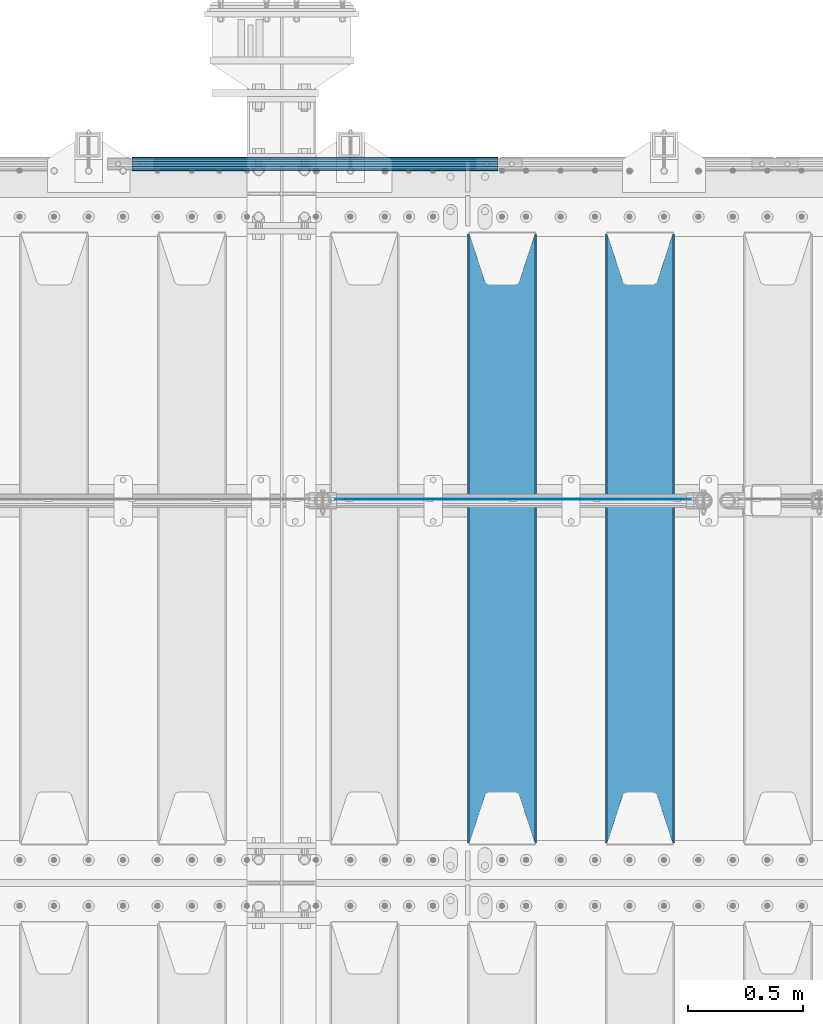
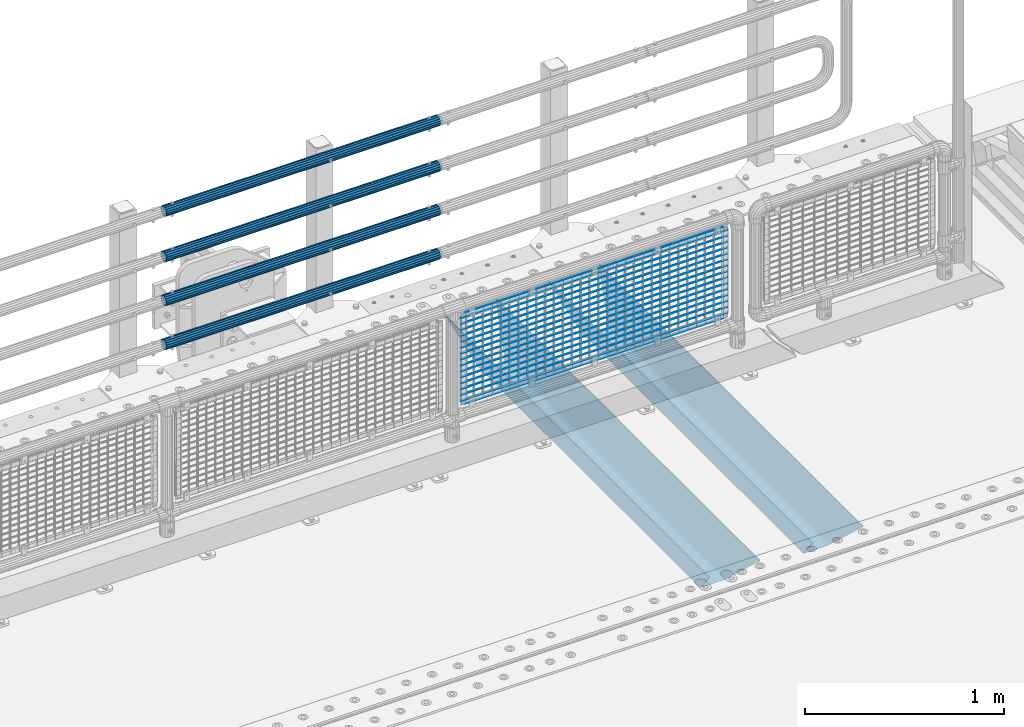
# One storey, part 100 of 193: 23 beams.
"""IFC2X3 building model written with IfcOpenShell, lengths in millimetres."""

from ifc_helpers import new_model, si_unit, frame, origin_with_axes, place, context, subcontext, project, spatial, faceted_brep, material, type_object, element, save


model = new_model("IFC2X3")

# Units and contexts
model_context = context("Model", 3, precision=1e-05, world=origin_with_axes())
body_context = subcontext(model_context, "Body", "Model", "MODEL_VIEW")
ifc_project = project(units=[si_unit("LENGTHUNIT", "METRE", prefix="MILLI"), si_unit("AREAUNIT", "SQUARE_METRE"), si_unit("VOLUMEUNIT", "CUBIC_METRE"), si_unit("MASSUNIT", "GRAM", prefix="KILO"), si_unit("TIMEUNIT", "SECOND"), si_unit("PLANEANGLEUNIT", "RADIAN"), si_unit("SOLIDANGLEUNIT", "STERADIAN"), si_unit("THERMODYNAMICTEMPERATUREUNIT", "DEGREE_CELSIUS"), si_unit("LUMINOUSINTENSITYUNIT", "LUMEN")], contexts=[model_context])

# Site, building, storey
site_placement = place(None, origin_with_axes())
site = spatial("IfcSite", under=ifc_project, at=site_placement, CompositionType="ELEMENT")
building_placement = place(site_placement, origin_with_axes())
building = spatial("IfcBuilding", under=site, at=building_placement, Name="Standard", CompositionType="ELEMENT")
storey_placement = place(building_placement, origin_with_axes())
storey = spatial("IfcBuildingStorey", under=building, at=storey_placement, Name="Undefined", CompositionType="ELEMENT", Elevation=0.0)

# Beams
ifc_material_1 = material(Name="STEEL/S355N")
beam_type_1 = type_object("IfcBeamType", PredefinedType="NOTDEFINED")
beam_1_placement = place(storey_placement, frame((-30500.0, 27175.0, -115.0), z_axis=(0.0, 0.0, 1.0), x_axis=(0.0, 1.0, 0.0)))
element("IfcBeam", 1, at=beam_1_placement, inside=storey, type_object=beam_type_1, material=ifc_material_1, context=body_context, shape_type="Brep", body=[
    faceted_brep([(0.0, 150.0, 115.0), (0.0, 143.689999999999, 115.0), (2650.00000000297, 143.689999999999, 115.0), (2650.00000000297, 150.0, 115.0), (2650.00000000297, 142.059565218398, 110.000000003094), (2650.00000000297, 148.3695652184, 110.000000003094), (2441.90079219209, -80.1103600731112, -98.0992078077845), (2437.7588105432, -77.5672621345584, -102.241189456673), (2434.06523489747, -74.4080125315522, -105.934765102404), (2430.9108609509, -70.710272125576, -109.089139048974), (2428.37322971128, -66.5649389910068, -111.626770288588), (2426.51472138055, -62.0739139532889, -113.485278619323), (2425.38102192092, -57.3475956567672, -114.618978078955), (2424.99999999988, -52.5021667386536, -115.0), (2424.99999999988, 52.5021667386536, -115.0), (2425.38102192092, 57.3475956567672, -114.618978078955), (2426.51472138055, 62.0739139532889, -113.485278619323), (2428.37322971128, 66.5649389910068, -111.626770288588), (2430.9108609509, 70.710272125576, -109.089139048974), (2434.06523489747, 74.4080125315522, -105.934765102404), (2437.7588105432, 77.5672621345584, -102.241189456673), (2441.90079219209, 80.1103600731112, -98.0992078077846), (2446.38936140512, 81.9747917625791, -93.6106385947584), (2448.2494850041, 76.2713538057251, -91.7505149957729), (2444.62967112263, 74.76777986261, -95.3703288772456), (2441.28936334127, 72.7168944282894, -98.710636658607), (2438.31067330439, 70.1691124903846, -101.689326695487), (2435.76682334748, 67.1870637758839, -104.233176652398), (2433.72034654134, 63.8440531834895, -106.279653458539), (2432.22154950042, 60.222258798236, -107.778450499454), (2431.30727574265, 56.4107117849089, -108.692724257221), (2430.99999999987, 52.5031078186876, -109.0), (2430.99999999987, -52.5031078186876, -109.0), (2431.30727574265, -56.4107117849089, -108.692724257221), (2432.22154950042, -60.222258798236, -107.778450499454), (2433.72034654134, -63.8440531834895, -106.279653458539), (2435.76682334748, -67.1870637758839, -104.233176652398), (2438.31067330439, -70.1691124903846, -101.689326695487), (2441.28936334127, -72.7168944282894, -98.7106366586071), (2444.62967112263, -74.76777986261, -95.3703288772457), (2448.2494850041, -76.2713538057251, -91.7505149957729), (2650.00000000297, -142.059565218398, 110.000000003094), (2650.00000000297, -148.3695652184, 110.000000003094), (2446.38936140512, -81.9747917625791, -93.6106385947584), (2650.00000000297, -143.689999999999, 115.0), (2650.00000000297, -150.0, 115.0), (0.0, -143.689999999999, 115.0), (0.0, -150.0, 115.0), (0.0, -148.369565218261, 110.000000002667), (203.610638597427, -81.9747917625791, -93.6106385947584), (208.099207810446, -80.1103600731112, -98.0992078077845), (212.241189459342, -77.5672621345584, -102.241189456673), (215.93476510507, -74.4080125315522, -105.934765102404), (219.089139051641, -70.710272125576, -109.089139048974), (221.626770291256, -66.5649389910068, -111.626770288588), (223.485278621989, -62.0739139532889, -113.485278619323), (224.618978081624, -57.3475956567672, -114.618978078955), (225.000000002663, -52.5021667386536, -115.0), (225.000000002663, 52.5021667386536, -115.0), (224.618978081624, 57.3475956567672, -114.618978078955), (223.485278621989, 62.0739139532889, -113.485278619323), (221.626770291256, 66.5649389910068, -111.626770288588), (219.089139051641, 70.710272125576, -109.089139048974), (215.93476510507, 74.4080125315522, -105.934765102404), (212.241189459342, 77.5672621345584, -102.241189456673), (208.099207810446, 80.1103600731112, -98.0992078077846), (203.610638597427, 81.9747917625791, -93.6106385947584), (0.0, 148.369565218261, 110.000000002667), (0.0, 142.05956521826, 110.000000002667), (201.750514998439, 76.2713538057251, -91.7505149957729), (205.370328879915, 74.76777986261, -95.3703288772456), (208.710636661275, 72.7168944282894, -98.710636658607), (211.689326698157, 70.1691124903846, -101.689326695487), (214.233176655063, 67.1870637758839, -104.233176652398), (216.279653461206, 63.8440531834895, -106.279653458539), (217.778450502123, 60.222258798236, -107.778450499454), (218.69272425989, 56.4107117849089, -108.692724257221), (219.00000000267, 52.5031078186876, -109.0), (219.00000000267, -52.5031078186876, -109.0), (218.69272425989, -56.4107117849089, -108.692724257221), (217.778450502123, -60.222258798236, -107.778450499454), (216.279653461206, -63.8440531834895, -106.279653458539), (214.233176655063, -67.1870637758839, -104.233176652398), (211.689326698157, -70.1691124903846, -101.689326695487), (208.710636661275, -72.7168944282894, -98.7106366586071), (205.370328879915, -74.76777986261, -95.3703288772457), (201.750514998439, -76.2713538057251, -91.7505149957729), (0.0, -142.05956521826, 110.000000002667)], [[[0, 1, 2, 3]], [[3, 2, 4, 5]], [[6, 7, 8, 9, 10, 11, 12, 13, 14, 15, 16, 17, 18, 19, 20, 21, 22, 5, 4, 23, 24, 25, 26, 27, 28, 29, 30, 31, 32, 33, 34, 35, 36, 37, 38, 39, 40, 41, 42, 43]], [[44, 45, 42, 41]], [[46, 47, 45, 44]], [[43, 42, 45, 47, 48, 49]], [[6, 43, 49, 50]], [[7, 6, 50, 51]], [[8, 7, 51, 52]], [[9, 8, 52, 53]], [[10, 9, 53, 54]], [[11, 10, 54, 55]], [[12, 11, 55, 56]], [[13, 12, 56, 57]], [[14, 13, 57, 58]], [[15, 14, 58, 59]], [[16, 15, 59, 60]], [[17, 16, 60, 61]], [[18, 17, 61, 62]], [[19, 18, 62, 63]], [[20, 19, 63, 64]], [[21, 20, 64, 65]], [[22, 21, 65, 66]], [[0, 3, 5, 22, 66, 67]], [[1, 0, 67, 68]], [[23, 4, 2, 1, 68, 69]], [[24, 23, 69, 70]], [[25, 24, 70, 71]], [[26, 25, 71, 72]], [[27, 26, 72, 73]], [[28, 27, 73, 74]], [[29, 28, 74, 75]], [[30, 29, 75, 76]], [[31, 30, 76, 77]], [[32, 31, 77, 78]], [[33, 32, 78, 79]], [[34, 33, 79, 80]], [[35, 34, 80, 81]], [[36, 35, 81, 82]], [[37, 36, 82, 83]], [[38, 37, 83, 84]], [[39, 38, 84, 85]], [[40, 39, 85, 86]], [[46, 44, 41, 40, 86, 87]], [[47, 46, 87, 48]], [[86, 85, 84, 83, 82, 81, 80, 79, 78, 77, 76, 75, 74, 73, 72, 71, 70, 69, 68, 67, 66, 65, 64, 63, 62, 61, 60, 59, 58, 57, 56, 55, 54, 53, 52, 51, 50, 49, 48, 87]]]),
])
beam_2_placement = place(storey_placement, frame((-31100.0, 27175.0, -115.0), z_axis=(0.0, 0.0, 1.0), x_axis=(0.0, 1.0, 0.0)))
element("IfcBeam", 2, at=beam_2_placement, inside=storey, type_object=beam_type_1, material=ifc_material_1, context=body_context, shape_type="Brep", body=[
    faceted_brep([(0.0, 150.0, 115.0), (0.0, 143.689999999999, 115.0), (2650.00000000297, 143.689999999999, 115.0), (2650.00000000297, 150.0, 115.0), (2650.00000000297, 142.059565218398, 110.000000003094), (2650.00000000297, 148.3695652184, 110.000000003094), (2441.90079219209, -80.1103600731112, -98.0992078077845), (2437.7588105432, -77.5672621345584, -102.241189456673), (2434.06523489747, -74.4080125315522, -105.934765102404), (2430.9108609509, -70.710272125576, -109.089139048974), (2428.37322971128, -66.5649389910068, -111.626770288588), (2426.51472138055, -62.0739139532889, -113.485278619323), (2425.38102192092, -57.3475956567672, -114.618978078955), (2424.99999999988, -52.5021667386536, -115.0), (2424.99999999988, 52.5021667386536, -115.0), (2425.38102192092, 57.3475956567672, -114.618978078955), (2426.51472138055, 62.0739139532889, -113.485278619323), (2428.37322971128, 66.5649389910068, -111.626770288588), (2430.9108609509, 70.710272125576, -109.089139048974), (2434.06523489747, 74.4080125315522, -105.934765102404), (2437.7588105432, 77.5672621345584, -102.241189456673), (2441.90079219209, 80.1103600731112, -98.0992078077846), (2446.38936140512, 81.9747917625791, -93.6106385947584), (2448.2494850041, 76.2713538057251, -91.7505149957729), (2444.62967112263, 74.76777986261, -95.3703288772456), (2441.28936334127, 72.7168944282894, -98.710636658607), (2438.31067330439, 70.1691124903846, -101.689326695487), (2435.76682334748, 67.1870637758839, -104.233176652398), (2433.72034654134, 63.8440531834895, -106.279653458539), (2432.22154950042, 60.222258798236, -107.778450499454), (2431.30727574265, 56.4107117849089, -108.692724257221), (2430.99999999987, 52.5031078186876, -109.0), (2430.99999999987, -52.5031078186876, -109.0), (2431.30727574265, -56.4107117849089, -108.692724257221), (2432.22154950042, -60.222258798236, -107.778450499454), (2433.72034654134, -63.8440531834895, -106.279653458539), (2435.76682334748, -67.1870637758839, -104.233176652398), (2438.31067330439, -70.1691124903846, -101.689326695487), (2441.28936334127, -72.7168944282894, -98.7106366586071), (2444.62967112263, -74.76777986261, -95.3703288772457), (2448.2494850041, -76.2713538057251, -91.7505149957729), (2650.00000000297, -142.059565218398, 110.000000003094), (2650.00000000297, -148.3695652184, 110.000000003094), (2446.38936140512, -81.9747917625791, -93.6106385947584), (2650.00000000297, -143.689999999999, 115.0), (2650.00000000297, -150.0, 115.0), (0.0, -143.689999999999, 115.0), (0.0, -150.0, 115.0), (0.0, -148.369565218261, 110.000000002667), (203.610638597427, -81.9747917625791, -93.6106385947584), (208.099207810446, -80.1103600731112, -98.0992078077845), (212.241189459342, -77.5672621345584, -102.241189456673), (215.93476510507, -74.4080125315522, -105.934765102404), (219.089139051641, -70.710272125576, -109.089139048974), (221.626770291256, -66.5649389910068, -111.626770288588), (223.485278621989, -62.0739139532889, -113.485278619323), (224.618978081624, -57.3475956567672, -114.618978078955), (225.000000002663, -52.5021667386536, -115.0), (225.000000002663, 52.5021667386536, -115.0), (224.618978081624, 57.3475956567672, -114.618978078955), (223.485278621989, 62.0739139532889, -113.485278619323), (221.626770291256, 66.5649389910068, -111.626770288588), (219.089139051641, 70.710272125576, -109.089139048974), (215.93476510507, 74.4080125315522, -105.934765102404), (212.241189459342, 77.5672621345584, -102.241189456673), (208.099207810446, 80.1103600731112, -98.0992078077846), (203.610638597427, 81.9747917625791, -93.6106385947584), (0.0, 148.369565218261, 110.000000002667), (0.0, 142.05956521826, 110.000000002667), (201.750514998439, 76.2713538057251, -91.7505149957729), (205.370328879915, 74.76777986261, -95.3703288772456), (208.710636661275, 72.7168944282894, -98.710636658607), (211.689326698157, 70.1691124903846, -101.689326695487), (214.233176655063, 67.1870637758839, -104.233176652398), (216.279653461206, 63.8440531834895, -106.279653458539), (217.778450502123, 60.222258798236, -107.778450499454), (218.69272425989, 56.4107117849089, -108.692724257221), (219.00000000267, 52.5031078186876, -109.0), (219.00000000267, -52.5031078186876, -109.0), (218.69272425989, -56.4107117849089, -108.692724257221), (217.778450502123, -60.222258798236, -107.778450499454), (216.279653461206, -63.8440531834895, -106.279653458539), (214.233176655063, -67.1870637758839, -104.233176652398), (211.689326698157, -70.1691124903846, -101.689326695487), (208.710636661275, -72.7168944282894, -98.7106366586071), (205.370328879915, -74.76777986261, -95.3703288772457), (201.750514998439, -76.2713538057251, -91.7505149957729), (0.0, -142.05956521826, 110.000000002667)], [[[0, 1, 2, 3]], [[3, 2, 4, 5]], [[6, 7, 8, 9, 10, 11, 12, 13, 14, 15, 16, 17, 18, 19, 20, 21, 22, 5, 4, 23, 24, 25, 26, 27, 28, 29, 30, 31, 32, 33, 34, 35, 36, 37, 38, 39, 40, 41, 42, 43]], [[44, 45, 42, 41]], [[46, 47, 45, 44]], [[43, 42, 45, 47, 48, 49]], [[6, 43, 49, 50]], [[7, 6, 50, 51]], [[8, 7, 51, 52]], [[9, 8, 52, 53]], [[10, 9, 53, 54]], [[11, 10, 54, 55]], [[12, 11, 55, 56]], [[13, 12, 56, 57]], [[14, 13, 57, 58]], [[15, 14, 58, 59]], [[16, 15, 59, 60]], [[17, 16, 60, 61]], [[18, 17, 61, 62]], [[19, 18, 62, 63]], [[20, 19, 63, 64]], [[21, 20, 64, 65]], [[22, 21, 65, 66]], [[0, 3, 5, 22, 66, 67]], [[1, 0, 67, 68]], [[23, 4, 2, 1, 68, 69]], [[24, 23, 69, 70]], [[25, 24, 70, 71]], [[26, 25, 71, 72]], [[27, 26, 72, 73]], [[28, 27, 73, 74]], [[29, 28, 74, 75]], [[30, 29, 75, 76]], [[31, 30, 76, 77]], [[32, 31, 77, 78]], [[33, 32, 78, 79]], [[34, 33, 79, 80]], [[35, 34, 80, 81]], [[36, 35, 81, 82]], [[37, 36, 82, 83]], [[38, 37, 83, 84]], [[39, 38, 84, 85]], [[40, 39, 85, 86]], [[46, 44, 41, 40, 86, 87]], [[47, 46, 87, 48]], [[86, 85, 84, 83, 82, 81, 80, 79, 78, 77, 76, 75, 74, 73, 72, 71, 70, 69, 68, 67, 66, 65, 64, 63, 62, 61, 60, 59, 58, 57, 56, 55, 54, 53, 52, 51, 50, 49, 48, 87]]]),
])
ifc_material_2 = material()
beam_type_2 = type_object("IfcBeamType", PredefinedType="NOTDEFINED")
beam_3_placement = place(storey_placement, frame((-31118.0000000001, 30129.8500000002, 149.849999999748), z_axis=(0.0, 0.0, -1.0), x_axis=(-1.0, 0.0, 0.0)))
element("IfcBeam", 3, at=beam_3_placement, inside=storey, type_object=beam_type_2, material=ifc_material_2, context=body_context, shape_type="Brep", body=[
    faceted_brep([(0.0, -26.5499999999993, 0.0), (0.0, -24.5290015881765, 10.1602451292931), (1594.0, -24.5290015881765, 10.1602451292931), (1594.0, -26.5499999999993, 0.0), (0.0, -18.7736850405017, 18.7736850405028), (1594.0, -18.7736850405017, 18.7736850405028), (0.0, -10.1602451292929, 24.5290015881747), (1594.0, -10.1602451292929, 24.5290015881747), (0.0, 0.0, 26.55), (1594.0, 0.0, 26.55), (0.0, 10.1602451292929, 24.5290015881747), (1594.0, 10.1602451292929, 24.5290015881747), (0.0, 18.7736850405017, 18.7736850405028), (1594.0, 18.7736850405017, 18.7736850405028), (0.0, 24.5290015881765, 10.1602451292931), (1594.0, 24.5290015881765, 10.1602451292931), (0.0, 26.5499999999993, 0.0), (1594.0, 26.5499999999993, 0.0), (0.0, 24.5290015881765, -10.1602451292931), (1594.0, 24.5290015881765, -10.1602451292931), (0.0, 18.7736850405017, -18.7736850405028), (1594.0, 18.7736850405017, -18.7736850405028), (0.0, 10.1602451292929, -24.5290015881747), (1594.0, 10.1602451292929, -24.5290015881747), (0.0, 0.0, -26.55), (1594.0, 0.0, -26.55), (0.0, -10.1602451292929, -24.5290015881747), (1594.0, -10.1602451292929, -24.5290015881747), (0.0, -18.7736850405017, -18.7736850405028), (1594.0, -18.7736850405017, -18.7736850405028), (0.0, -24.5290015881765, -10.1602451292931), (1594.0, -24.5290015881765, -10.1602451292931), (0.0, -30.1500000000015, 0.0), (0.0, -27.8549679052157, -11.5379054858058), (1594.0, -27.8549679052157, -11.5379054858075), (1594.0, -30.1500000000015, 0.0), (0.0, -21.3192694527752, -21.3192694527752), (1594.0, -21.3192694527752, -21.3192694527744), (0.0, -11.5379054858058, -27.8549679052157), (1594.0, -11.5379054858058, -27.8549679052153), (0.0, 0.0, -30.1500000000015), (1594.0, 0.0, -30.15), (0.0, 11.5379054858058, -27.8549679052157), (1594.0, 11.5379054858058, -27.8549679052153), (0.0, 21.3192694527752, -21.3192694527752), (1594.0, 21.3192694527752, -21.3192694527744), (0.0, 27.8549679052157, -11.5379054858058), (1594.0, 27.8549679052157, -11.5379054858074), (0.0, 30.1500000000015, 0.0), (1594.0, 30.1500000000015, 0.0), (0.0, 27.8549679052157, 11.5379054858058), (1594.0, 27.8549679052157, 11.5379054858075), (0.0, 21.3192694527752, 21.3192694527752), (1594.0, 21.3192694527752, 21.3192694527744), (0.0, 11.5379054858058, 27.8549679052157), (1594.0, 11.5379054858058, 27.8549679052153), (0.0, 0.0, 30.1500000000015), (1594.0, 0.0, 30.15), (0.0, -11.5379054858058, 27.8549679052157), (1594.0, -11.5379054858058, 27.8549679052153), (0.0, -21.3192694527752, 21.3192694527752), (1594.0, -21.3192694527752, 21.3192694527744), (0.0, -27.8549679052157, 11.5379054858058), (1594.0, -27.8549679052157, 11.5379054858075)], [[[0, 1, 2, 3]], [[1, 4, 5, 2]], [[4, 6, 7, 5]], [[6, 8, 9, 7]], [[8, 10, 11, 9]], [[10, 12, 13, 11]], [[12, 14, 15, 13]], [[14, 16, 17, 15]], [[16, 18, 19, 17]], [[18, 20, 21, 19]], [[20, 22, 23, 21]], [[22, 24, 25, 23]], [[24, 26, 27, 25]], [[26, 28, 29, 27]], [[28, 30, 31, 29]], [[30, 0, 3, 31]], [[32, 33, 34, 35]], [[33, 36, 37, 34]], [[36, 38, 39, 37]], [[38, 40, 41, 39]], [[40, 42, 43, 41]], [[42, 44, 45, 43]], [[44, 46, 47, 45]], [[46, 48, 49, 47]], [[48, 50, 51, 49]], [[50, 52, 53, 51]], [[52, 54, 55, 53]], [[54, 56, 57, 55]], [[56, 58, 59, 57]], [[58, 60, 61, 59]], [[60, 62, 63, 61]], [[62, 32, 35, 63]], [[37, 39, 41, 43, 45, 47, 49, 51, 53, 55, 57, 59, 61, 63, 35, 34], [5, 7, 9, 11, 13, 15, 17, 19, 21, 23, 25, 27, 29, 31, 3, 2]], [[62, 60, 58, 56, 54, 52, 50, 48, 46, 44, 42, 40, 38, 36, 33, 32], [30, 28, 26, 24, 22, 20, 18, 16, 14, 12, 10, 8, 6, 4, 1, 0]]]),
])
beam_4_placement = place(storey_placement, frame((-31118.0000000001, 30129.8500000002, 420.149999999748), z_axis=(0.0, 0.0, -1.0), x_axis=(-1.0, 0.0, 0.0)))
element("IfcBeam", 4, at=beam_4_placement, inside=storey, type_object=beam_type_2, material=ifc_material_2, context=body_context, shape_type="Brep", body=[
    faceted_brep([(0.0, -26.5499999999993, 0.0), (0.0, -24.5290015881765, 10.1602451292931), (1594.0, -24.5290015881765, 10.1602451292931), (1594.0, -26.5499999999993, 0.0), (0.0, -18.7736850405017, 18.7736850405028), (1594.0, -18.7736850405017, 18.7736850405028), (0.0, -10.1602451292929, 24.5290015881747), (1594.0, -10.1602451292929, 24.5290015881747), (0.0, 0.0, 26.55), (1594.0, 0.0, 26.55), (0.0, 10.1602451292929, 24.5290015881747), (1594.0, 10.1602451292929, 24.5290015881747), (0.0, 18.7736850405017, 18.7736850405028), (1594.0, 18.7736850405017, 18.7736850405028), (0.0, 24.5290015881765, 10.1602451292931), (1594.0, 24.5290015881765, 10.1602451292931), (0.0, 26.5499999999993, 0.0), (1594.0, 26.5499999999993, 0.0), (0.0, 24.5290015881765, -10.1602451292931), (1594.0, 24.5290015881765, -10.1602451292931), (0.0, 18.7736850405017, -18.7736850405028), (1594.0, 18.7736850405017, -18.7736850405028), (0.0, 10.1602451292929, -24.5290015881747), (1594.0, 10.1602451292929, -24.5290015881747), (0.0, 0.0, -26.55), (1594.0, 0.0, -26.55), (0.0, -10.1602451292929, -24.5290015881747), (1594.0, -10.1602451292929, -24.5290015881747), (0.0, -18.7736850405017, -18.7736850405028), (1594.0, -18.7736850405017, -18.7736850405028), (0.0, -24.5290015881765, -10.1602451292931), (1594.0, -24.5290015881765, -10.1602451292931), (0.0, -30.1500000000015, 0.0), (0.0, -27.8549679052157, -11.5379054858058), (1594.0, -27.8549679052157, -11.5379054858075), (1594.0, -30.1500000000015, 0.0), (0.0, -21.3192694527752, -21.3192694527752), (1594.0, -21.3192694527752, -21.3192694527744), (0.0, -11.5379054858058, -27.8549679052157), (1594.0, -11.5379054858058, -27.8549679052153), (0.0, 0.0, -30.1500000000015), (1594.0, 0.0, -30.15), (0.0, 11.5379054858058, -27.8549679052157), (1594.0, 11.5379054858058, -27.8549679052153), (0.0, 21.3192694527752, -21.3192694527752), (1594.0, 21.3192694527752, -21.3192694527744), (0.0, 27.8549679052157, -11.5379054858058), (1594.0, 27.8549679052157, -11.5379054858074), (0.0, 30.1500000000015, 0.0), (1594.0, 30.1500000000015, 0.0), (0.0, 27.8549679052157, 11.5379054858058), (1594.0, 27.8549679052157, 11.5379054858075), (0.0, 21.3192694527752, 21.3192694527752), (1594.0, 21.3192694527752, 21.3192694527744), (0.0, 11.5379054858058, 27.8549679052157), (1594.0, 11.5379054858058, 27.8549679052153), (0.0, 0.0, 30.1500000000015), (1594.0, 0.0, 30.15), (0.0, -11.5379054858058, 27.8549679052157), (1594.0, -11.5379054858058, 27.8549679052153), (0.0, -21.3192694527752, 21.3192694527752), (1594.0, -21.3192694527752, 21.3192694527744), (0.0, -27.8549679052157, 11.5379054858058), (1594.0, -27.8549679052157, 11.5379054858075)], [[[0, 1, 2, 3]], [[1, 4, 5, 2]], [[4, 6, 7, 5]], [[6, 8, 9, 7]], [[8, 10, 11, 9]], [[10, 12, 13, 11]], [[12, 14, 15, 13]], [[14, 16, 17, 15]], [[16, 18, 19, 17]], [[18, 20, 21, 19]], [[20, 22, 23, 21]], [[22, 24, 25, 23]], [[24, 26, 27, 25]], [[26, 28, 29, 27]], [[28, 30, 31, 29]], [[30, 0, 3, 31]], [[32, 33, 34, 35]], [[33, 36, 37, 34]], [[36, 38, 39, 37]], [[38, 40, 41, 39]], [[40, 42, 43, 41]], [[42, 44, 45, 43]], [[44, 46, 47, 45]], [[46, 48, 49, 47]], [[48, 50, 51, 49]], [[50, 52, 53, 51]], [[52, 54, 55, 53]], [[54, 56, 57, 55]], [[56, 58, 59, 57]], [[58, 60, 61, 59]], [[60, 62, 63, 61]], [[62, 32, 35, 63]], [[37, 39, 41, 43, 45, 47, 49, 51, 53, 55, 57, 59, 61, 63, 35, 34], [5, 7, 9, 11, 13, 15, 17, 19, 21, 23, 25, 27, 29, 31, 3, 2]], [[62, 60, 58, 56, 54, 52, 50, 48, 46, 44, 42, 40, 38, 36, 33, 32], [30, 28, 26, 24, 22, 20, 18, 16, 14, 12, 10, 8, 6, 4, 1, 0]]]),
])
beam_5_placement = place(storey_placement, frame((-31118.0000000001, 30129.8500000002, 969.849999999748), z_axis=(0.0, 0.0, -1.0), x_axis=(-1.0, 0.0, 0.0)))
element("IfcBeam", 5, at=beam_5_placement, inside=storey, type_object=beam_type_2, material=ifc_material_2, context=body_context, shape_type="Brep", body=[
    faceted_brep([(0.0, -26.5499999999993, 0.0), (0.0, -24.5290015881765, 10.1602451292931), (1594.0, -24.5290015881765, 10.1602451292931), (1594.0, -26.5499999999993, 0.0), (0.0, -18.7736850405017, 18.7736850405028), (1594.0, -18.7736850405017, 18.7736850405028), (0.0, -10.1602451292929, 24.5290015881747), (1594.0, -10.1602451292929, 24.5290015881747), (0.0, 0.0, 26.55), (1594.0, 0.0, 26.55), (0.0, 10.1602451292929, 24.5290015881747), (1594.0, 10.1602451292929, 24.5290015881747), (0.0, 18.7736850405017, 18.7736850405028), (1594.0, 18.7736850405017, 18.7736850405028), (0.0, 24.5290015881765, 10.1602451292931), (1594.0, 24.5290015881765, 10.1602451292931), (0.0, 26.5499999999993, 0.0), (1594.0, 26.5499999999993, 0.0), (0.0, 24.5290015881765, -10.1602451292931), (1594.0, 24.5290015881765, -10.1602451292931), (0.0, 18.7736850405017, -18.7736850405028), (1594.0, 18.7736850405017, -18.7736850405028), (0.0, 10.1602451292929, -24.5290015881747), (1594.0, 10.1602451292929, -24.5290015881747), (0.0, 0.0, -26.55), (1594.0, 0.0, -26.55), (0.0, -10.1602451292929, -24.5290015881747), (1594.0, -10.1602451292929, -24.5290015881747), (0.0, -18.7736850405017, -18.7736850405028), (1594.0, -18.7736850405017, -18.7736850405028), (0.0, -24.5290015881765, -10.1602451292931), (1594.0, -24.5290015881765, -10.1602451292931), (0.0, -30.1500000000015, 0.0), (0.0, -27.8549679052157, -11.5379054858058), (1594.0, -27.8549679052157, -11.5379054858075), (1594.0, -30.1500000000015, 0.0), (0.0, -21.3192694527752, -21.3192694527752), (1594.0, -21.3192694527752, -21.3192694527744), (0.0, -11.5379054858058, -27.8549679052157), (1594.0, -11.5379054858058, -27.8549679052153), (0.0, 0.0, -30.1500000000015), (1594.0, 0.0, -30.15), (0.0, 11.5379054858058, -27.8549679052157), (1594.0, 11.5379054858058, -27.8549679052153), (0.0, 21.3192694527752, -21.3192694527752), (1594.0, 21.3192694527752, -21.3192694527744), (0.0, 27.8549679052157, -11.5379054858058), (1594.0, 27.8549679052157, -11.5379054858074), (0.0, 30.1500000000015, 0.0), (1594.0, 30.1500000000015, 0.0), (0.0, 27.8549679052157, 11.5379054858058), (1594.0, 27.8549679052157, 11.5379054858075), (0.0, 21.3192694527752, 21.3192694527752), (1594.0, 21.3192694527752, 21.3192694527744), (0.0, 11.5379054858058, 27.8549679052157), (1594.0, 11.5379054858058, 27.8549679052153), (0.0, 0.0, 30.1500000000015), (1594.0, 0.0, 30.15), (0.0, -11.5379054858058, 27.8549679052157), (1594.0, -11.5379054858058, 27.8549679052153), (0.0, -21.3192694527752, 21.3192694527752), (1594.0, -21.3192694527752, 21.3192694527744), (0.0, -27.8549679052157, 11.5379054858058), (1594.0, -27.8549679052157, 11.5379054858075)], [[[0, 1, 2, 3]], [[1, 4, 5, 2]], [[4, 6, 7, 5]], [[6, 8, 9, 7]], [[8, 10, 11, 9]], [[10, 12, 13, 11]], [[12, 14, 15, 13]], [[14, 16, 17, 15]], [[16, 18, 19, 17]], [[18, 20, 21, 19]], [[20, 22, 23, 21]], [[22, 24, 25, 23]], [[24, 26, 27, 25]], [[26, 28, 29, 27]], [[28, 30, 31, 29]], [[30, 0, 3, 31]], [[32, 33, 34, 35]], [[33, 36, 37, 34]], [[36, 38, 39, 37]], [[38, 40, 41, 39]], [[40, 42, 43, 41]], [[42, 44, 45, 43]], [[44, 46, 47, 45]], [[46, 48, 49, 47]], [[48, 50, 51, 49]], [[50, 52, 53, 51]], [[52, 54, 55, 53]], [[54, 56, 57, 55]], [[56, 58, 59, 57]], [[58, 60, 61, 59]], [[60, 62, 63, 61]], [[62, 32, 35, 63]], [[37, 39, 41, 43, 45, 47, 49, 51, 53, 55, 57, 59, 61, 63, 35, 34], [5, 7, 9, 11, 13, 15, 17, 19, 21, 23, 25, 27, 29, 31, 3, 2]], [[62, 60, 58, 56, 54, 52, 50, 48, 46, 44, 42, 40, 38, 36, 33, 32], [30, 28, 26, 24, 22, 20, 18, 16, 14, 12, 10, 8, 6, 4, 1, 0]]]),
])
beam_6_placement = place(storey_placement, frame((-31118.0000000001, 30129.8500000002, 689.849999999748), z_axis=(0.0, 0.0, -1.0), x_axis=(-1.0, 0.0, 0.0)))
element("IfcBeam", 6, at=beam_6_placement, inside=storey, type_object=beam_type_2, material=ifc_material_2, context=body_context, shape_type="Brep", body=[
    faceted_brep([(0.0, -26.5499999999993, 0.0), (0.0, -24.5290015881765, 10.1602451292931), (1594.0, -24.5290015881765, 10.1602451292931), (1594.0, -26.5499999999993, 0.0), (0.0, -18.7736850405017, 18.7736850405028), (1594.0, -18.7736850405017, 18.7736850405028), (0.0, -10.1602451292929, 24.5290015881747), (1594.0, -10.1602451292929, 24.5290015881747), (0.0, 0.0, 26.55), (1594.0, 0.0, 26.55), (0.0, 10.1602451292929, 24.5290015881747), (1594.0, 10.1602451292929, 24.5290015881747), (0.0, 18.7736850405017, 18.7736850405028), (1594.0, 18.7736850405017, 18.7736850405028), (0.0, 24.5290015881765, 10.1602451292931), (1594.0, 24.5290015881765, 10.1602451292931), (0.0, 26.5499999999993, 0.0), (1594.0, 26.5499999999993, 0.0), (0.0, 24.5290015881765, -10.1602451292931), (1594.0, 24.5290015881765, -10.1602451292931), (0.0, 18.7736850405017, -18.7736850405028), (1594.0, 18.7736850405017, -18.7736850405028), (0.0, 10.1602451292929, -24.5290015881747), (1594.0, 10.1602451292929, -24.5290015881747), (0.0, 0.0, -26.55), (1594.0, 0.0, -26.55), (0.0, -10.1602451292929, -24.5290015881747), (1594.0, -10.1602451292929, -24.5290015881747), (0.0, -18.7736850405017, -18.7736850405028), (1594.0, -18.7736850405017, -18.7736850405028), (0.0, -24.5290015881765, -10.1602451292931), (1594.0, -24.5290015881765, -10.1602451292931), (0.0, -30.1500000000015, 0.0), (0.0, -27.8549679052157, -11.5379054858058), (1594.0, -27.8549679052157, -11.5379054858075), (1594.0, -30.1500000000015, 0.0), (0.0, -21.3192694527752, -21.3192694527752), (1594.0, -21.3192694527752, -21.3192694527744), (0.0, -11.5379054858058, -27.8549679052157), (1594.0, -11.5379054858058, -27.8549679052153), (0.0, 0.0, -30.1500000000015), (1594.0, 0.0, -30.15), (0.0, 11.5379054858058, -27.8549679052157), (1594.0, 11.5379054858058, -27.8549679052153), (0.0, 21.3192694527752, -21.3192694527752), (1594.0, 21.3192694527752, -21.3192694527744), (0.0, 27.8549679052157, -11.5379054858058), (1594.0, 27.8549679052157, -11.5379054858074), (0.0, 30.1500000000015, 0.0), (1594.0, 30.1500000000015, 0.0), (0.0, 27.8549679052157, 11.5379054858058), (1594.0, 27.8549679052157, 11.5379054858075), (0.0, 21.3192694527752, 21.3192694527752), (1594.0, 21.3192694527752, 21.3192694527744), (0.0, 11.5379054858058, 27.8549679052157), (1594.0, 11.5379054858058, 27.8549679052153), (0.0, 0.0, 30.1500000000015), (1594.0, 0.0, 30.15), (0.0, -11.5379054858058, 27.8549679052157), (1594.0, -11.5379054858058, 27.8549679052153), (0.0, -21.3192694527752, 21.3192694527752), (1594.0, -21.3192694527752, 21.3192694527744), (0.0, -27.8549679052157, 11.5379054858058), (1594.0, -27.8549679052157, 11.5379054858075)], [[[0, 1, 2, 3]], [[1, 4, 5, 2]], [[4, 6, 7, 5]], [[6, 8, 9, 7]], [[8, 10, 11, 9]], [[10, 12, 13, 11]], [[12, 14, 15, 13]], [[14, 16, 17, 15]], [[16, 18, 19, 17]], [[18, 20, 21, 19]], [[20, 22, 23, 21]], [[22, 24, 25, 23]], [[24, 26, 27, 25]], [[26, 28, 29, 27]], [[28, 30, 31, 29]], [[30, 0, 3, 31]], [[32, 33, 34, 35]], [[33, 36, 37, 34]], [[36, 38, 39, 37]], [[38, 40, 41, 39]], [[40, 42, 43, 41]], [[42, 44, 45, 43]], [[44, 46, 47, 45]], [[46, 48, 49, 47]], [[48, 50, 51, 49]], [[50, 52, 53, 51]], [[52, 54, 55, 53]], [[54, 56, 57, 55]], [[56, 58, 59, 57]], [[58, 60, 61, 59]], [[60, 62, 63, 61]], [[62, 32, 35, 63]], [[37, 39, 41, 43, 45, 47, 49, 51, 53, 55, 57, 59, 61, 63, 35, 34], [5, 7, 9, 11, 13, 15, 17, 19, 21, 23, 25, 27, 29, 31, 3, 2]], [[62, 60, 58, 56, 54, 52, 50, 48, 46, 44, 42, 40, 38, 36, 33, 32], [30, 28, 26, 24, 22, 20, 18, 16, 14, 12, 10, 8, 6, 4, 1, 0]]]),
])
ifc_material_3 = material(Name="Misc_Undefined")
beam_type_3 = type_object("IfcBeamType", Name="D3", PredefinedType="NOTDEFINED")
for number, where, z_axis, x_axis in (
    (7, (-31826.0, 28670.5, 851.597000000001), (0.0, 0.0, 1.0), (1.0, 0.0, 0.0)),
    (8, (-31826.0, 28670.5, 669.452000000001), (0.0, 0.0, 1.0), (1.0, 0.0, 0.0)),
    (9, (-31826.0, 28670.5, 523.736000000001), (0.0, 0.0, 1.0), (1.0, 0.0, 0.0)),
    (10, (-31826.0, 28670.5, 487.307000000001), (0.0, 0.0, 1.0), (1.0, 0.0, 0.0)),
    (11, (-31826.0, 28670.5, 705.881000000001), (0.0, 0.0, 1.0), (1.0, 0.0, 0.0)),
    (12, (-31826.0, 28670.5, 596.594000000001), (0.0, 0.0, 1.0), (1.0, 0.0, 0.0)),
    (13, (-31826.0, 28670.5, 450.878000000001), (0.0, 0.0, 1.0), (1.0, 0.0, 0.0)),
    (14, (-31826.0, 28670.5, 815.168000000001), (0.0, 0.0, 1.0), (1.0, 0.0, 0.0)),
    (15, (-31826.0, 28670.5, 888.026000000001), (0.0, 0.0, 1.0), (1.0, 0.0, 0.0)),
    (16, (-31826.0, 28670.5, 778.739000000001), (0.0, 0.0, 1.0), (1.0, 0.0, 0.0)),
    (17, (-31826.0, 28670.5, 742.310000000001), (0.0, 0.0, 1.0), (1.0, 0.0, 0.0)),
    (18, (-31826.0, 28670.5, 633.023000000001), (0.0, 0.0, 1.0), (1.0, 0.0, 0.0)),
    (19, (-31826.0, 28670.5, 560.165000000001), (0.0, 0.0, 1.0), (1.0, 0.0, 0.0)),
    (20, (-31826.0, 28670.5, 414.449000000001), (0.0, 0.0, 1.0), (1.0, 0.0, 0.0)),
):
    element("IfcBeam", number, at=place(storey_placement, frame(where, z_axis=z_axis, x_axis=x_axis)), inside=storey, type_object=beam_type_3, material=ifc_material_3, ObjectType="D3", context=body_context, shape_type="Brep", body=[
        faceted_brep([(0.0, -1.49999999999636, 3.63797880709171e-12), (0.0, -0.75, -1.29903810567669), (1548.0, -0.75, -1.29903810567669), (1548.0, -1.5, 0.0), (0.0, 0.75, -1.29903810567669), (1548.0, 0.75, -1.29903810567669), (0.0, 1.50000000000364, 7.27595761418343e-12), (1548.0, 1.5, 0.0), (0.0, 0.75, 1.29903810567669), (1548.0, 0.75, 1.29903810567669), (0.0, -0.75, 1.29903810567669), (1548.0, -0.75, 1.29903810567669)], [[[0, 1, 2, 3]], [[1, 4, 5, 2]], [[4, 6, 7, 5]], [[6, 8, 9, 7]], [[8, 10, 11, 9]], [[10, 0, 3, 11]], [[5, 7, 9, 11, 3, 2]], [[10, 8, 6, 4, 1, 0]]]),
    ])
beam_7_placement = place(storey_placement, frame((-31801.0, 28670.5, 353.020000000001), z_axis=(0.0, 0.0, 1.0), x_axis=(1.0, 0.0, 0.0)))
element("IfcBeam", 21, at=beam_7_placement, inside=storey, type_object=beam_type_3, material=ifc_material_3, ObjectType="D3", context=body_context, shape_type="Brep", body=[
    faceted_brep([(0.0, -1.49999999999636, 3.63797880709171e-12), (0.0, -0.75, -1.29903810567669), (1498.0, -0.75, -1.29903810567669), (1498.0, -1.5, 0.0), (0.0, 0.75, -1.29903810567669), (1498.0, 0.75, -1.29903810567663), (0.0, 1.50000000000364, 7.27595761418343e-12), (1498.0, 1.5, 0.0), (0.0, 0.75, 1.29903810567669), (1498.0, 0.75, 1.29903810567669), (0.0, -0.75, 1.29903810567669), (1498.0, -0.75, 1.29903810567669)], [[[0, 1, 2, 3]], [[1, 4, 5, 2]], [[4, 6, 7, 5]], [[6, 8, 9, 7]], [[8, 10, 11, 9]], [[10, 0, 3, 11]], [[5, 7, 9, 11, 3, 2]], [[10, 8, 6, 4, 1, 0]]]),
])
beam_8_placement = place(storey_placement, frame((-31826.0, 28670.5, 378.020000000001), z_axis=(0.0, 0.0, 1.0), x_axis=(1.0, 0.0, 0.0)))
element("IfcBeam", 22, at=beam_8_placement, inside=storey, type_object=beam_type_3, material=ifc_material_3, ObjectType="D3", context=body_context, shape_type="Brep", body=[
    faceted_brep([(0.0, -1.49999999999636, 3.63797880709171e-12), (0.0, -0.75, -1.29903810567669), (1548.0, -0.75, -1.29903810567669), (1548.0, -1.5, 0.0), (0.0, 0.75, -1.29903810567669), (1548.0, 0.75, -1.29903810567669), (0.0, 1.50000000000364, 7.27595761418343e-12), (1548.0, 1.5, 0.0), (0.0, 0.75, 1.29903810567669), (1548.0, 0.75, 1.29903810567669), (0.0, -0.75, 1.29903810567669), (1548.0, -0.75, 1.29903810567669)], [[[0, 1, 2, 3]], [[1, 4, 5, 2]], [[4, 6, 7, 5]], [[6, 8, 9, 7]], [[8, 10, 11, 9]], [[10, 0, 3, 11]], [[5, 7, 9, 11, 3, 2]], [[10, 8, 6, 4, 1, 0]]]),
])
beam_9_placement = place(storey_placement, frame((-31801.0, 28670.5, 913.020000000001), z_axis=(0.0, 0.0, 1.0), x_axis=(1.0, 0.0, 0.0)))
element("IfcBeam", 23, at=beam_9_placement, inside=storey, type_object=beam_type_3, material=ifc_material_3, ObjectType="D3", context=body_context, shape_type="Brep", body=[
    faceted_brep([(0.0, -1.49999999999636, 3.63797880709171e-12), (0.0, -0.75, -1.29903810567669), (1498.0, -0.75, -1.29903810567669), (1498.0, -1.5, 0.0), (0.0, 0.75, -1.29903810567669), (1498.0, 0.75, -1.29903810567663), (0.0, 1.50000000000364, 7.27595761418343e-12), (1498.0, 1.5, 0.0), (0.0, 0.75, 1.29903810567669), (1498.0, 0.75, 1.29903810567669), (0.0, -0.75, 1.29903810567669), (1498.0, -0.75, 1.29903810567669)], [[[0, 1, 2, 3]], [[1, 4, 5, 2]], [[4, 6, 7, 5]], [[6, 8, 9, 7]], [[8, 10, 11, 9]], [[10, 0, 3, 11]], [[5, 7, 9, 11, 3, 2]], [[10, 8, 6, 4, 1, 0]]]),
])

save(model, "model.ifc")
